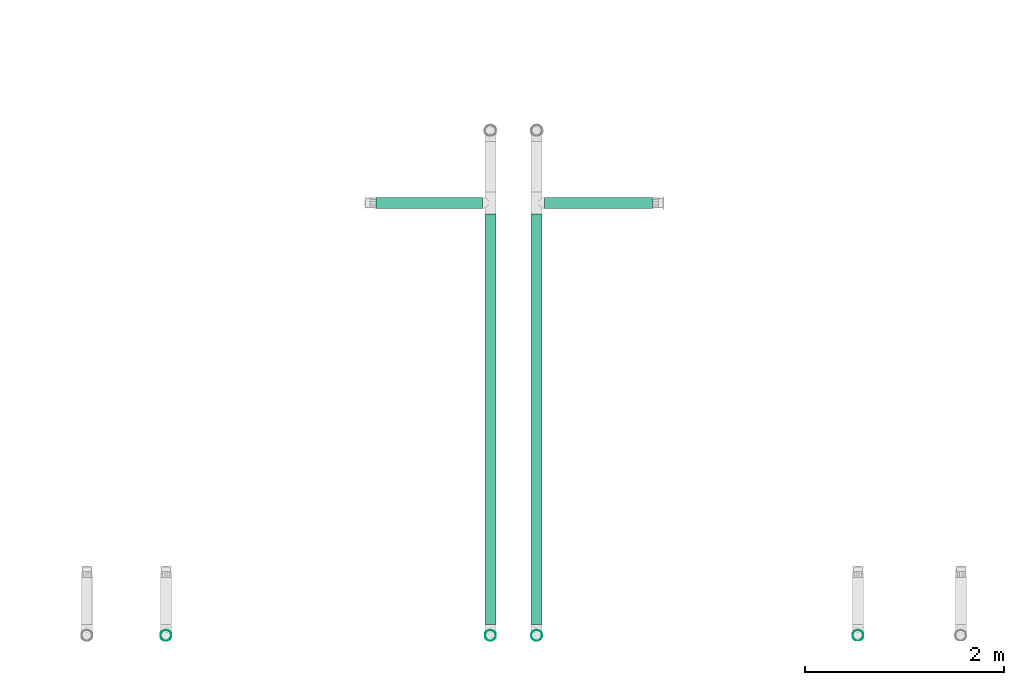
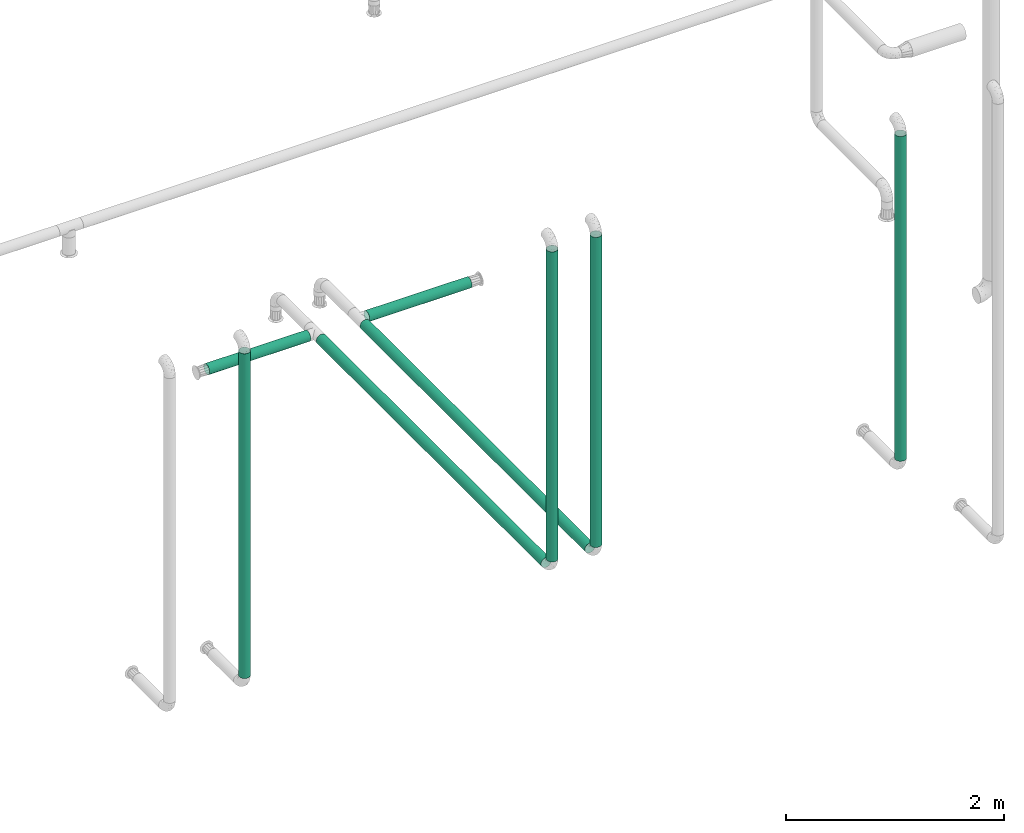
# One storey, part 7 of 115: 8 flow segments.
"""IFC2X3 building model written with IfcOpenShell, lengths in millimetres."""

from ifc_helpers import new_model, entity, si_unit, converted_unit, derived_unit, direction, frame, origin_with_axes, origin_2d_with_axis, place, context, subcontext, project, spatial, hollow_circle, extrude, source, transform, mapped, material, layer, layer_set, layer_usage, type_object, element, save


model = new_model("IFC2X3")

# Units and contexts
model_context = context("Model", 3, precision=1e-05, world=origin_with_axes(), true_north=direction((0.0, 1.0)))
body_context = subcontext(model_context, "Body", "Model", "MODEL_VIEW")
ifc_project = project(units=[si_unit("AREAUNIT", "SQUARE_METRE"), si_unit("VOLUMEUNIT", "CUBIC_METRE", prefix="DECI"), si_unit("TIMEUNIT", "SECOND"), si_unit("THERMODYNAMICTEMPERATUREUNIT", "DEGREE_CELSIUS"), si_unit("PRESSUREUNIT", "PASCAL"), si_unit("MASSUNIT", "GRAM", prefix="KILO"), si_unit("LENGTHUNIT", "METRE", prefix="MILLI"), si_unit("POWERUNIT", "WATT"), si_unit("ELECTRICCURRENTUNIT", "AMPERE"), si_unit("ELECTRICVOLTAGEUNIT", "VOLT"), derived_unit("VOLUMETRICFLOWRATEUNIT", [(si_unit("VOLUMEUNIT", "CUBIC_METRE", prefix="DECI"), 1), (si_unit("TIMEUNIT", "SECOND"), -1)]), derived_unit("LINEARVELOCITYUNIT", [(si_unit("LENGTHUNIT", "METRE"), 1), (si_unit("TIMEUNIT", "SECOND"), -1)]), derived_unit("MASSDENSITYUNIT", [(si_unit("MASSUNIT", "GRAM", prefix="KILO"), 1), (si_unit("VOLUMEUNIT", "CUBIC_METRE"), -1)]), converted_unit("PLANEANGLEUNIT", "DEGREE", entity("IfcRatioMeasure", 0.01745), si_unit("PLANEANGLEUNIT", "RADIAN"), dimensions=[0, 0, 0, 0, 0, 0, 0])], contexts=[model_context])

# Site, building, storey
site_placement = place(None, origin_with_axes())
site = spatial("IfcSite", under=ifc_project, at=site_placement, CompositionType="ELEMENT")
building_placement = place(site_placement, origin_with_axes())
building = spatial("IfcBuilding", under=site, at=building_placement, Name="mc-building", CompositionType="ELEMENT")
storey_placement = place(building_placement, frame((0.0, 0.0, 2950.0), z_axis=(0.0, 0.0, 1.0), x_axis=(1.0, 0.0, 0.0)))
storey = spatial("IfcBuildingStorey", under=building, at=storey_placement, Name="2. Korrus", CompositionType="ELEMENT", Elevation=2950.0)

# Flow segments
ifc_material = material(Name="FZ1")
ifc_layer = layer(ifc_material, 0.0)
ifc_layer_set = layer_set([ifc_layer], Name="FZ1")
ifc_layer_usage = layer_usage(ifc_layer_set, "AXIS1", "POSITIVE", 0.0)
duct_segment_type_1 = type_object("IfcDuctSegmentType", PredefinedType="RIGIDSEGMENT")
shared_shape_1 = source(origin_with_axes(), body_context, "Body", "SweptSolid", [
    extrude(hollow_circle(Radius=55.0, WallThickness=2.0, at=origin_2d_with_axis()), frame((0.0, 0.0, 0.0), z_axis=(1.0, 0.0, 0.0), x_axis=(0.0, 1.0, 0.0)), (0.0, 0.0, 1.0), 3480.0),
])
for number, where, z_axis, x_axis in (
    (1, (30053.28275, -687.64676, 2575.0), (1.0, 0.0, 0.0), (0.0, 0.0, 1.0)),
    (2, (30518.54047, -687.64676, 2575.0), (1.0, 0.0, 0.0), (0.0, 0.0, 1.0)),
):
    element("IfcFlowSegment", number, at=place(storey_placement, frame(where, z_axis=z_axis, x_axis=x_axis)), inside=storey, type_object=duct_segment_type_1, material=ifc_layer_usage, context=body_context, shape_type="MappedRepresentation", body=[
        mapped(shared_shape_1, transform((0.0, 0.0, 0.0), scale=1.0)),
    ])
duct_segment_type_2 = type_object("IfcDuctSegmentType", Name="Safe", PredefinedType="RIGIDSEGMENT")
shared_shape_2 = source(origin_with_axes(), body_context, "Body", "SweptSolid", [
    extrude(hollow_circle(Radius=55.0, WallThickness=2.0, at=origin_2d_with_axis()), frame((0.0, 0.0, 0.0), z_axis=(1.0, 0.0, 0.0), x_axis=(0.0, 1.0, 0.0)), (0.0, 0.0, 1.0), 3645.0),
])
for number, where, z_axis, x_axis, name in (
    (3, (26787.42189, -687.64676, 2410.0), (1.0, 0.0, 0.0), (0.0, 0.0, 1.0), "Safe"),
    (4, (33752.94253, -687.64676, 2410.0), (1.0, 0.0, 0.0), (0.0, 0.0, 1.0), "Safe"),
):
    element("IfcFlowSegment", number, at=place(storey_placement, frame(where, z_axis=z_axis, x_axis=x_axis)), inside=storey, type_object=duct_segment_type_2, material=ifc_layer_usage, Name=name, context=body_context, shape_type="MappedRepresentation", body=[
        mapped(shared_shape_2, transform((0.0, 0.0, 0.0), scale=1.0)),
    ])
shared_shape_3 = source(origin_with_axes(), body_context, "Body", "SweptSolid", [
    extrude(hollow_circle(Radius=55.0, WallThickness=2.0, at=origin_2d_with_axis()), frame((0.0, 0.0, 0.0), z_axis=(1.0, 0.0, 0.0), x_axis=(0.0, 1.0, 0.0)), (0.0, 0.0, 1.0), 1074.2),
])
flow_segment_1_placement = place(storey_placement, frame((29973.28275, 3666.26111, 2465.0), z_axis=(0.0, 0.0, 1.0), x_axis=(-1.0, 0.0, 0.0)))
element("IfcFlowSegment", 5, at=flow_segment_1_placement, inside=storey, type_object=duct_segment_type_1, material=ifc_layer_usage, context=body_context, shape_type="MappedRepresentation", body=[
    mapped(shared_shape_3, transform((0.0, 0.0, 0.0), scale=1.0)),
])
shared_shape_4 = source(origin_with_axes(), body_context, "Body", "SweptSolid", [
    extrude(hollow_circle(Radius=55.0, WallThickness=2.0, at=origin_2d_with_axis()), frame((0.0, 0.0, 0.0), z_axis=(1.0, 0.0, 0.0), x_axis=(0.0, 1.0, 0.0)), (0.0, 0.0, 1.0), 4133.9),
])
for number, where, z_axis, x_axis in (
    (6, (30053.28275, -577.64676, 2465.0), (0.0, 0.0, 1.0), (0.0, 1.0, 0.0)),
    (7, (30518.54047, -577.64676, 2465.0), (0.0, 0.0, 1.0), (0.0, 1.0, 0.0)),
):
    element("IfcFlowSegment", number, at=place(storey_placement, frame(where, z_axis=z_axis, x_axis=x_axis)), inside=storey, type_object=duct_segment_type_1, material=ifc_layer_usage, context=body_context, shape_type="MappedRepresentation", body=[
        mapped(shared_shape_4, transform((0.0, 0.0, 0.0), scale=1.0)),
    ])
shared_shape_5 = source(origin_with_axes(), body_context, "Body", "SweptSolid", [
    extrude(hollow_circle(Radius=55.0, WallThickness=2.0, at=origin_2d_with_axis()), frame((0.0, 0.0, 0.0), z_axis=(1.0, 0.0, 0.0), x_axis=(0.0, 1.0, 0.0)), (0.0, 0.0, 1.0), 1086.3),
])
flow_segment_2_placement = place(storey_placement, frame((30598.54047, 3666.26111, 2465.0), z_axis=(0.0, 0.0, 1.0), x_axis=(1.0, 0.0, 0.0)))
element("IfcFlowSegment", 8, at=flow_segment_2_placement, inside=storey, type_object=duct_segment_type_1, material=ifc_layer_usage, context=body_context, shape_type="MappedRepresentation", body=[
    mapped(shared_shape_5, transform((0.0, 0.0, 0.0), scale=1.0)),
])

save(model, "model.ifc")
